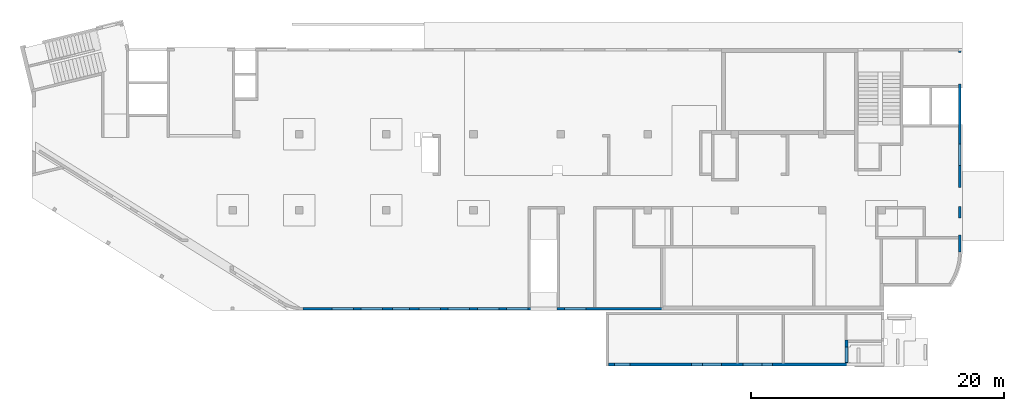
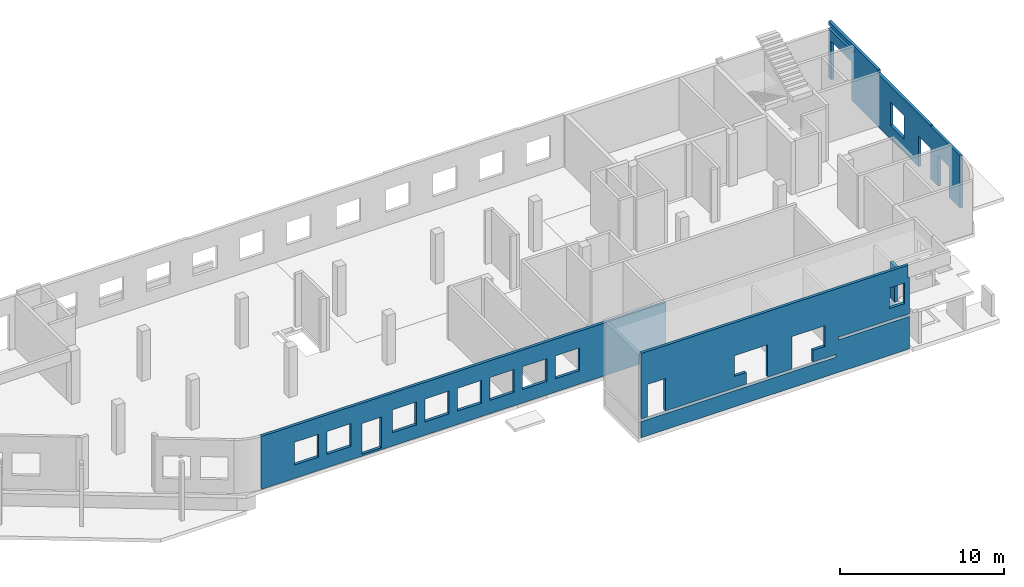
# One storey, part 7 of 8: 4 walls, 13 openings.
"""IFC4 building model written with IfcOpenShell, lengths in millimetres."""

import ifcopenshell
import ifcopenshell.guid

model = None  # the IFC model being written
_history = None  # IfcOwnerHistory: only IFC2X3 demands one
_inside = {}  # id of a spatial element -> (the spatial element, [elements in it])
_under = {}  # id of a project, library or spatial element -> (it, [spatial elements below it])
_declared = {}  # id of a project -> (the project, [libraries it declares])
_typed = {}  # id of a type object -> (the type object, [elements of that type])
_made_of = {}  # id of a material, layer set ... -> (it, [elements and type objects made of it])


def new_model(schema):
    """Start an empty IFC model of exactly this schema.

    Asked for "IFC4X3", IfcOpenShell would pick the latest addendum, in which some entities
    have other attributes; the version numbers below select the first issue.
    IFC2X3 requires an IfcOwnerHistory on every rooted entity: one is made here for all.
    """
    global model, _history
    if schema == "IFC4X3":
        model = ifcopenshell.file(schema_version=(4, 3, 0, 0))
    else:
        model = ifcopenshell.file(schema=schema)
    _inside.clear()
    _under.clear()
    _declared.clear()
    _typed.clear()
    _made_of.clear()
    _history = None
    if model.schema == "IFC2X3":
        org = make("IfcOrganization", Name="unknown")
        user = make(
            "IfcPersonAndOrganization",
            ThePerson=make("IfcPerson", FamilyName="unknown"),
            TheOrganization=org,
        )
        app = make(
            "IfcApplication",
            ApplicationDeveloper=org,
            Version="unknown",
            ApplicationFullName="unknown",
            ApplicationIdentifier="unknown",
        )
        _history = make(
            "IfcOwnerHistory",
            OwningUser=user,
            OwningApplication=app,
            ChangeAction="ADDED",
            CreationDate=0,
        )
    return model


def make(cls, **values):
    """One entity of the class cls with the attributes given. An attribute that is None is left unset."""
    return model.create_entity(
        cls, **{name: value for name, value in values.items() if value is not None}
    )


def entity(cls, *values):
    """Any entity or typed value of the class cls, its attributes in the order of the schema. None: left unset."""
    e = model.create_entity(cls)
    for i, value in enumerate(values):
        if value is not None:
            e[i] = value
    return e


def rooted(cls, **values):
    """An entity with a GlobalId (a new one), such as an element, a storey or a relation."""
    return make(cls, GlobalId=ifcopenshell.guid.new(), OwnerHistory=_history, **values)


def si_unit(unit_type, name, prefix=None):
    """IfcSIUnit, for example si_unit("LENGTHUNIT", "METRE", prefix="MILLI")."""
    return make("IfcSIUnit", UnitType=unit_type, Prefix=prefix, Name=name)


def converted_unit(unit_type, name, factor, base, dimensions=None, offset=None):
    """IfcConversionBasedUnit, such as the inch: factor (a typed value) times the base unit."""
    return make(
        "IfcConversionBasedUnit"
        if offset is None
        else "IfcConversionBasedUnitWithOffset",
        ConversionOffset=offset,
        Dimensions=None
        if dimensions is None
        else entity("IfcDimensionalExponents", *dimensions),
        UnitType=unit_type,
        Name=name,
        ConversionFactor=make(
            "IfcMeasureWithUnit", ValueComponent=factor, UnitComponent=base
        ),
    )


def derived_unit(unit_type, elements):
    """IfcDerivedUnit: a product of units, each with its exponent."""
    return make(
        "IfcDerivedUnit",
        Elements=[
            make("IfcDerivedUnitElement", Unit=unit, Exponent=power)
            for unit, power in elements
        ],
        UnitType=unit_type,
    )


def assignment(units):
    """IfcUnitAssignment: the units of a project."""
    return None if units is None else make("IfcUnitAssignment", Units=units)


def point(xyz):
    """IfcCartesianPoint."""
    return None if xyz is None else make("IfcCartesianPoint", Coordinates=xyz)


def direction(xyz):
    """IfcDirection."""
    return None if xyz is None else make("IfcDirection", DirectionRatios=xyz)


def frame(location, z_axis=None, x_axis=None):
    """IfcAxis2Placement3D, a coordinate frame: its origin and axes. An axis left out is left unset."""
    return make(
        "IfcAxis2Placement3D",
        Location=point(location),
        Axis=direction(z_axis),
        RefDirection=direction(x_axis),
    )


def origin():
    """The frame at (0, 0, 0) with its axes left unset."""
    return frame((0.0, 0.0, 0.0))


def place(relative_to, where):
    """IfcLocalPlacement: puts the frame where relative to a parent placement (None: the world)."""
    return make(
        "IfcLocalPlacement", PlacementRelTo=relative_to, RelativePlacement=where
    )


def context(
    kind, dimensions, precision=None, world=None, true_north=None, identifier=None
):
    """IfcGeometricRepresentationContext, for example the 3D "Model" context."""
    return make(
        "IfcGeometricRepresentationContext",
        ContextIdentifier=identifier,
        ContextType=kind,
        CoordinateSpaceDimension=dimensions,
        Precision=precision,
        WorldCoordinateSystem=world,
        TrueNorth=true_north,
    )


def subcontext(parent, identifier, kind, view, scale=None):
    """IfcGeometricRepresentationSubContext, for example "Body" below "Model"."""
    return make(
        "IfcGeometricRepresentationSubContext",
        ContextIdentifier=identifier,
        ContextType=kind,
        ParentContext=parent,
        TargetScale=scale,
        TargetView=view,
    )


def project(units=None, contexts=None):
    """IfcProject with its units and contexts."""
    return rooted(
        "IfcProject",
        Name="project",
        RepresentationContexts=contexts,
        UnitsInContext=assignment(units),
    )


def spatial(cls, under=None, at=None, **own):
    """A site, building, storey or space (cls), placed at a placement, below another one or the project."""
    s = rooted(cls, ObjectPlacement=at, **own)
    if under is not None:
        _under.setdefault(under.id(), (under, []))[1].append(s)
    return s


def point_list(points):
    """IfcCartesianPointList2D or 3D."""
    cls = (
        "IfcCartesianPointList2D" if len(points[0]) == 2 else "IfcCartesianPointList3D"
    )
    return make(cls, CoordList=points)


def indexed_curve(points, segments=None, self_intersect=None):
    """IfcIndexedPolyCurve: lines and arcs through numbered points (the first is 1)."""
    return make(
        "IfcIndexedPolyCurve",
        Points=point_list(points),
        Segments=segments,
        SelfIntersect=self_intersect,
    )


def outline(outer, holes=None, kind="AREA"):
    """IfcArbitraryClosedProfileDef: a profile drawn as a closed curve; with holes, ...WithVoids."""
    if holes is None:
        return make("IfcArbitraryClosedProfileDef", ProfileType=kind, OuterCurve=outer)
    return make(
        "IfcArbitraryProfileDefWithVoids",
        ProfileType=kind,
        OuterCurve=outer,
        InnerCurves=holes,
    )


def extrude(swept, where, along, depth):
    """IfcExtrudedAreaSolid: the profile swept, set in the frame where, extruded along a direction by depth."""
    return make(
        "IfcExtrudedAreaSolid",
        SweptArea=swept,
        Position=where,
        ExtrudedDirection=direction(along),
        Depth=depth,
    )


def polygons(points, faces, closed=None, point_numbers=None):
    """IfcPolygonalFaceSet: a face is its outer loop, then its inner loops; points numbered from 1."""
    made = []
    for loops in faces:
        if len(loops) == 1:
            made.append(make("IfcIndexedPolygonalFace", CoordIndex=loops[0]))
        else:
            made.append(
                make(
                    "IfcIndexedPolygonalFaceWithVoids",
                    CoordIndex=loops[0],
                    InnerCoordIndices=loops[1:],
                )
            )
    return make(
        "IfcPolygonalFaceSet",
        Coordinates=point_list(points),
        Closed=closed,
        Faces=made,
        PnIndex=point_numbers,
    )


def shape(context_of_items, identifier, shape_type, items):
    """IfcShapeRepresentation: the items that make up one representation, for example the "Body"."""
    return make(
        "IfcShapeRepresentation",
        ContextOfItems=context_of_items,
        RepresentationIdentifier=identifier,
        RepresentationType=shape_type,
        Items=items,
    )


def material(Name=None, Category=None):
    """IfcMaterial."""
    return make("IfcMaterial", Name=Name, Category=Category)


def made_of(thing, what):
    """Note that an element or type object is made of a material, layer set ...; save() writes the relation."""
    if what is not None:
        _made_of.setdefault(what.id(), (what, []))[1].append(thing)
    return thing


def type_object(cls, material=None, **own):
    """A type object (cls), such as IfcWallType, which elements share."""
    return made_of(rooted(cls, **own), material)


def element(
    cls,
    number,
    at=None,
    inside=None,
    cuts=None,
    type_object=None,
    material=None,
    context=None,
    identifier="Body",
    shape_type=None,
    held_by="IfcProductDefinitionShape",
    body=None,
    shapes=None,
    **own,
):
    """One element of the class cls, such as IfcWall. Its Tag is "e" and its number.

    at: its placement. inside: the storey or other place that contains it. cuts: it is an
    opening in that element (IfcRelVoidsElement). A single representation is given by context,
    identifier, shape_type and body (its items); several are given by shapes. held_by: the class
    of the entity that holds the representations. save() writes the other relations.
    """
    e = rooted(cls, Tag="e%d" % number, ObjectPlacement=at, **own)
    if body is not None:
        shapes = [shape(context, identifier, shape_type, body)]
    if shapes is not None:
        e.Representation = make(held_by, Representations=shapes)
    if inside is not None:
        _inside.setdefault(inside.id(), (inside, []))[1].append(e)
    if cuts is not None:
        rooted(
            "IfcRelVoidsElement", RelatingBuildingElement=cuts, RelatedOpeningElement=e
        )
    if type_object is not None:
        _typed.setdefault(type_object.id(), (type_object, []))[1].append(e)
    return made_of(e, material)


def aggregate(whole, parts):
    """IfcRelAggregates: a whole, such as a stair, and the parts it consists of."""
    return rooted("IfcRelAggregates", RelatingObject=whole, RelatedObjects=parts)


def save(model, path):
    """Write the relations noted so far, then the file.

    IfcRelAggregates (storeys below a building ...), IfcRelContainedInSpatialStructure (elements
    in a storey), IfcRelDefinesByType, IfcRelAssociatesMaterial and IfcRelDeclares: one each for
    every whole, place, type object, material and project.
    """
    for whole, parts in _under.values():
        aggregate(whole, parts)
    for where, things in _inside.values():
        rooted(
            "IfcRelContainedInSpatialStructure",
            RelatedElements=things,
            RelatingStructure=where,
        )
    for kind, things in _typed.values():
        rooted("IfcRelDefinesByType", RelatedObjects=things, RelatingType=kind)
    for what, things in _made_of.values():
        rooted("IfcRelAssociatesMaterial", RelatedObjects=things, RelatingMaterial=what)
    for by, libraries in _declared.values():
        rooted("IfcRelDeclares", RelatingContext=by, RelatedDefinitions=libraries)
    model.write(path)


model = new_model("IFC4")

# Units and contexts
model_context = context("Model", 3, precision=0.01, world=origin(), true_north=direction((6.12303176911189e-17, 1.0)))
plan_context = context("Plan", 3, precision=0.01, world=origin(), true_north=direction((6.12303176911189e-17, 1.0)))
body_context = subcontext(model_context, "Body", "Model", "MODEL_VIEW")
ifc_project = project(units=[si_unit("LENGTHUNIT", "METRE", prefix="MILLI"), si_unit("AREAUNIT", "SQUARE_METRE"), si_unit("VOLUMEUNIT", "CUBIC_METRE"), converted_unit("PLANEANGLEUNIT", "DEGREE", entity("IfcRatioMeasure", 0.0174532925199433), si_unit("PLANEANGLEUNIT", "RADIAN"), dimensions=[0, 0, 0, 0, 0, 0, 0]), si_unit("MASSUNIT", "GRAM", prefix="KILO"), derived_unit("MASSDENSITYUNIT", [(si_unit("MASSUNIT", "GRAM", prefix="KILO"), 1), (si_unit("LENGTHUNIT", "METRE"), -3)]), derived_unit("MOMENTOFINERTIAUNIT", [(si_unit("LENGTHUNIT", "METRE"), 4)]), si_unit("TIMEUNIT", "SECOND"), si_unit("FREQUENCYUNIT", "HERTZ"), si_unit("THERMODYNAMICTEMPERATUREUNIT", "DEGREE_CELSIUS"), derived_unit("THERMALTRANSMITTANCEUNIT", [(si_unit("MASSUNIT", "GRAM", prefix="KILO"), 1), (si_unit("THERMODYNAMICTEMPERATUREUNIT", "KELVIN"), -1), (si_unit("TIMEUNIT", "SECOND"), -3)]), derived_unit("VOLUMETRICFLOWRATEUNIT", [(si_unit("LENGTHUNIT", "METRE"), 3), (si_unit("TIMEUNIT", "SECOND"), -1)]), derived_unit("MASSFLOWRATEUNIT", [(si_unit("MASSUNIT", "GRAM", prefix="KILO"), 1), (si_unit("TIMEUNIT", "SECOND"), -1)]), derived_unit("ROTATIONALFREQUENCYUNIT", [(si_unit("TIMEUNIT", "SECOND"), -1)]), si_unit("ELECTRICCURRENTUNIT", "AMPERE"), si_unit("ELECTRICVOLTAGEUNIT", "VOLT"), si_unit("POWERUNIT", "WATT"), si_unit("FORCEUNIT", "NEWTON", prefix="KILO"), si_unit("ILLUMINANCEUNIT", "LUX"), si_unit("LUMINOUSFLUXUNIT", "LUMEN"), si_unit("LUMINOUSINTENSITYUNIT", "CANDELA"), derived_unit("USERDEFINED", [(si_unit("MASSUNIT", "GRAM", prefix="KILO"), -1), (si_unit("LENGTHUNIT", "METRE"), -2), (si_unit("TIMEUNIT", "SECOND"), 3), (si_unit("LUMINOUSFLUXUNIT", "LUMEN"), 1)]), derived_unit("LINEARVELOCITYUNIT", [(si_unit("LENGTHUNIT", "METRE"), 1), (si_unit("TIMEUNIT", "SECOND"), -1)]), si_unit("PRESSUREUNIT", "PASCAL"), derived_unit("USERDEFINED", [(si_unit("LENGTHUNIT", "METRE"), -2), (si_unit("MASSUNIT", "GRAM", prefix="KILO"), 1), (si_unit("TIMEUNIT", "SECOND"), -2)]), derived_unit("LINEARFORCEUNIT", [(si_unit("MASSUNIT", "GRAM", prefix="KILO"), 1), (si_unit("LENGTHUNIT", "METRE"), 1), (si_unit("TIMEUNIT", "SECOND"), -2), (si_unit("LENGTHUNIT", "METRE"), -1)]), derived_unit("PLANARFORCEUNIT", [(si_unit("MASSUNIT", "GRAM", prefix="KILO"), 1), (si_unit("LENGTHUNIT", "METRE"), 1), (si_unit("TIMEUNIT", "SECOND"), -2), (si_unit("LENGTHUNIT", "METRE"), -2)])], contexts=[model_context, plan_context])

# Site, building, storey
site_placement = place(None, origin())
site = spatial("IfcSite", under=ifc_project, at=site_placement, CompositionType="ELEMENT")
building_placement = place(site_placement, origin())
building = spatial("IfcBuilding", under=site, at=building_placement, CompositionType="ELEMENT")
storey_placement = place(building_placement, origin())
storey = spatial("IfcBuildingStorey", under=building, at=storey_placement, CompositionType="ELEMENT", Elevation=0.0)

# Wall, openings
ifc_material = material()
wall_type = type_object("IfcWallType", PredefinedType="STANDARD")
wall_1_placement = place(storey_placement, frame((21465.0002685546, -100.000773643746, -150.0)))
wall_1 = element("IfcWall", 1, at=wall_1_placement, inside=storey, type_object=wall_type, material=ifc_material, PredefinedType="NOTDEFINED", context=body_context, shape_type="Tessellation", body=[
    polygons([(6.46220325391393e-13, -100.0, 0.0), (28405.0, -100.0, 0.0), (28405.0, -100.0, 150.0), (28505.0, -100.0, 150.0), (28505.0, -100.0, 3950.0), (6.46220325391393e-13, -100.0, 3950.0), (20705.0, -100.0, 2700.0), (22405.0, -100.0, 2700.0), (22405.0, -100.0, 1000.00000000001), (20705.0, -100.0, 1000.00000000001), (2305.00000000005, -100.0, 2700.0), (4005.00000000005, -100.0, 2700.0), (4005.00000000005, -100.0, 1000.00000000001), (2305.00000000005, -100.0, 1000.00000000001), (4605.00000000006, -100.0, 2700.0), (6305.00000000006, -100.0, 2700.0), (6305.00000000006, -100.0, 1000.00000000001), (4605.00000000006, -100.0, 1000.00000000001), (9205.00000000005, -100.0, 2700.0), (10905.0000000001, -100.0, 2700.0), (10905.0000000001, -100.0, 1000.00000000001), (9205.00000000005, -100.0, 1000.00000000001), (11505.0000000001, -100.0, 2700.0), (13205.0000000001, -100.0, 2700.0), (13205.0000000001, -100.0, 1000.00000000001), (11505.0000000001, -100.0, 1000.00000000001), (13805.0, -100.0, 2700.0), (15505.0, -100.0, 2700.0), (15505.0, -100.0, 1000.00000000001), (13805.0, -100.0, 1000.00000000001), (16105.0000000001, -100.0, 2700.0), (17805.0000000001, -100.0, 2700.0), (17805.0000000001, -100.0, 1000.00000000001), (16105.0000000001, -100.0, 1000.00000000001), (18405.0000000001, -100.0, 2700.0), (20105.0, -100.0, 2700.0), (20105.0, -100.0, 1000.00000000001), (18405.0000000001, -100.0, 1000.00000000001), (7080.00000000006, -100.0, 2429.99999999804), (8430.00000000005, -100.0, 2429.99999999805), (8430.00000000005, -100.0, 150.0), (7080.00000000006, -100.0, 150.0), (28405.0, 100.0, 0.0), (2.4997118955433e-18, 100.0, 0.0), (2.4997118955433e-18, 100.0, 3950.0), (4154.99999999999, 100.0, 3950.0), (4454.99999999999, 100.0, 3950.0), (8855.0, 100.0, 3950.0), (9155.0, 100.0, 3950.0), (13365.0, 100.0, 3950.0), (13665.0, 100.0, 3950.0), (18180.0, 100.0, 3950.0), (18380.0, 100.0, 3950.0), (22605.0, 100.0, 3950.0), (22805.0, 100.0, 3950.0), (28505.0, 100.0, 3950.0), (28505.0, 100.0, 150.0), (28405.0, 100.0, 150.0), (22405.0, 100.000000000321, 2700.0), (20705.0, 100.000000000321, 2700.0), (20705.0, 100.000000000321, 1000.00000000001), (22405.0, 100.000000000321, 1000.00000000001), (4005.00000000005, 100.000000000321, 2700.0), (2305.00000000005, 100.000000000321, 2700.0), (2305.00000000005, 100.000000000321, 1000.00000000001), (4005.00000000005, 100.000000000321, 1000.00000000001), (6305.00000000006, 100.000000000321, 2700.0), (4605.00000000006, 100.000000000321, 2700.0), (4605.00000000006, 100.000000000321, 1000.00000000001), (6305.00000000006, 100.000000000321, 1000.00000000001), (10905.0000000001, 100.000000000321, 2700.0), (9205.00000000005, 100.000000000321, 2700.0), (9205.00000000005, 100.000000000321, 1000.00000000001), (10905.0000000001, 100.000000000321, 1000.00000000001), (13205.0000000001, 100.000000000321, 2700.0), (11505.0000000001, 100.000000000321, 2700.0), (11505.0000000001, 100.000000000321, 1000.00000000001), (13205.0000000001, 100.000000000321, 1000.00000000001), (15505.0, 100.000000000321, 2700.0), (13805.0, 100.000000000321, 2700.0), (13805.0, 100.000000000321, 1000.00000000001), (15505.0, 100.000000000321, 1000.00000000001), (17805.0000000001, 100.000000000321, 2700.0), (16105.0000000001, 100.000000000321, 2700.0), (16105.0000000001, 100.000000000321, 1000.00000000001), (17805.0000000001, 100.000000000321, 1000.00000000001), (20105.0, 100.000000000321, 2700.0), (18405.0000000001, 100.000000000321, 2700.0), (18405.0000000001, 100.000000000321, 1000.00000000001), (20105.0, 100.000000000321, 1000.00000000001), (8430.00000000006, 100.0, 2429.99999999804), (7080.00000000006, 100.0, 2429.99999999804), (7080.00000000006, 100.0, 150.0), (8430.00000000006, 100.0, 150.0)], [[[1, 2, 3, 4, 5, 6], [7, 8, 9, 10], [11, 12, 13, 14], [15, 16, 17, 18], [19, 20, 21, 22], [23, 24, 25, 26], [27, 28, 29, 30], [31, 32, 33, 34], [35, 36, 37, 38], [39, 40, 41, 42]], [[43, 44, 45, 46, 47, 48, 49, 50, 51, 52, 53, 54, 55, 56, 57, 58], [59, 60, 61, 62], [63, 64, 65, 66], [67, 68, 69, 70], [71, 72, 73, 74], [75, 76, 77, 78], [79, 80, 81, 82], [83, 84, 85, 86], [87, 88, 89, 90], [91, 92, 93, 94]], [[2, 1, 44, 43]], [[44, 1, 6, 45]], [[6, 5, 56, 55, 54, 53, 52, 51, 50, 49, 48, 47, 46, 45]], [[2, 43, 58, 3]], [[4, 3, 58, 57]], [[4, 57, 56, 5]], [[60, 59, 8, 7]], [[60, 7, 10, 61]], [[61, 10, 9, 62]], [[8, 59, 62, 9]], [[64, 63, 12, 11]], [[64, 11, 14, 65]], [[65, 14, 13, 66]], [[12, 63, 66, 13]], [[68, 67, 16, 15]], [[68, 15, 18, 69]], [[69, 18, 17, 70]], [[16, 67, 70, 17]], [[72, 71, 20, 19]], [[72, 19, 22, 73]], [[73, 22, 21, 74]], [[20, 71, 74, 21]], [[76, 75, 24, 23]], [[76, 23, 26, 77]], [[77, 26, 25, 78]], [[24, 75, 78, 25]], [[80, 79, 28, 27]], [[80, 27, 30, 81]], [[81, 30, 29, 82]], [[28, 79, 82, 29]], [[84, 83, 32, 31]], [[84, 31, 34, 85]], [[85, 34, 33, 86]], [[32, 83, 86, 33]], [[88, 87, 36, 35]], [[88, 35, 38, 89]], [[89, 38, 37, 90]], [[36, 87, 90, 37]], [[91, 40, 39, 92]], [[92, 39, 42, 93]], [[93, 42, 41, 94]], [[40, 91, 94, 41]]], closed=True),
])
opening_1_placement = place(wall_1_placement, frame((-21465.0002685546, 100.000773643746, 150.0)))
element("IfcOpeningElement", 2, at=opening_1_placement, cuts=wall_1, PredefinedType="OPENING", context=body_context, shape_type="SweptSolid", body=[
    extrude(outline(indexed_curve([(-849.999999999994, -850.000000000006), (849.999999999994, -850.000000000006), (849.999999999994, 849.999999999997), (-849.999999999994, 849.999999999997), (-849.999999999994, -850.000000000006)], self_intersect=False)), frame((40720.0002685547, -200.000773643808, 1700.0), z_axis=(0.0, 1.0, 0.0), x_axis=(0.0, 0.0, -1.0)), (0.0, 0.0, 1.0), 200.000000000962),
])
opening_2_placement = place(wall_1_placement, frame((-21465.0002685546, 100.000773643746, 150.0)))
element("IfcOpeningElement", 3, at=opening_2_placement, cuts=wall_1, PredefinedType="OPENING", context=body_context, shape_type="SweptSolid", body=[
    extrude(outline(indexed_curve([(-849.999999999994, -850.000000000002), (849.999999999994, -850.000000000002), (849.999999999994, 849.999999999997), (-849.999999999994, 849.999999999997), (-849.999999999994, -850.000000000002)], self_intersect=False)), frame((38420.0002685547, -200.0007736438, 1700.0), z_axis=(0.0, 1.0, 0.0), x_axis=(0.0, 0.0, -1.0)), (0.0, 0.0, 1.0), 200.000000000962),
])
opening_3_placement = place(wall_1_placement, frame((-21465.0002685546, 100.000773643746, 150.0)))
element("IfcOpeningElement", 4, at=opening_3_placement, cuts=wall_1, PredefinedType="OPENING", context=body_context, shape_type="SweptSolid", body=[
    extrude(outline(indexed_curve([(-849.999999999994, -850.000000000002), (849.999999999994, -850.000000000002), (849.999999999994, 849.999999999997), (-849.999999999994, 849.999999999997), (-849.999999999994, -850.000000000002)], self_intersect=False)), frame((36120.0002685547, -200.000773643793, 1700.0), z_axis=(0.0, 1.0, 0.0), x_axis=(0.0, 0.0, -1.0)), (0.0, 0.0, 1.0), 200.000000000962),
])
opening_4_placement = place(wall_1_placement, frame((-21465.0002685546, 100.000773643746, 150.0)))
element("IfcOpeningElement", 5, at=opening_4_placement, cuts=wall_1, PredefinedType="OPENING", context=body_context, shape_type="SweptSolid", body=[
    extrude(outline(indexed_curve([(-849.999999999994, -850.000000000002), (849.999999999994, -850.000000000002), (849.999999999994, 849.999999999997), (-849.999999999994, 849.999999999997), (-849.999999999994, -850.000000000002)], self_intersect=False)), frame((33820.0002685547, -200.000773643785, 1700.0), z_axis=(0.0, 1.0, 0.0), x_axis=(0.0, 0.0, -1.0)), (0.0, 0.0, 1.0), 200.000000000962),
])
opening_5_placement = place(wall_1_placement, frame((-21465.0002685546, 100.000773643746, 150.0)))
element("IfcOpeningElement", 6, at=opening_5_placement, cuts=wall_1, PredefinedType="OPENING", context=body_context, shape_type="SweptSolid", body=[
    extrude(outline(indexed_curve([(-849.999999999994, -849.999999999997), (849.999999999994, -849.999999999997), (849.999999999994, 850.000000000002), (-849.999999999994, 850.000000000002), (-849.999999999994, -849.999999999997)], self_intersect=False)), frame((31520.0002685547, -200.000773643778, 1700.0), z_axis=(0.0, 1.0, 0.0), x_axis=(0.0, 0.0, -1.0)), (0.0, 0.0, 1.0), 200.000000000962),
])
opening_6_placement = place(wall_1_placement, frame((-21465.0002685546, 100.000773643746, 150.0)))
element("IfcOpeningElement", 7, at=opening_6_placement, cuts=wall_1, PredefinedType="OPENING", context=body_context, shape_type="SweptSolid", body=[
    extrude(outline(indexed_curve([(-849.999999999994, -850.000000000002), (849.999999999994, -850.000000000002), (849.999999999994, 849.999999999997), (-849.999999999994, 849.999999999997), (-849.999999999994, -850.000000000002)], self_intersect=False)), frame((26920.0002685547, -200.000773643763, 1700.0), z_axis=(0.0, 1.0, 0.0), x_axis=(0.0, 0.0, -1.0)), (0.0, 0.0, 1.0), 200.000000000962),
])
opening_7_placement = place(wall_1_placement, frame((-21465.0002685546, 100.000773643746, 150.0)))
element("IfcOpeningElement", 8, at=opening_7_placement, cuts=wall_1, PredefinedType="OPENING", context=body_context, shape_type="SweptSolid", body=[
    extrude(outline(indexed_curve([(-849.999999999994, -850.000000000002), (849.999999999994, -850.000000000002), (849.999999999994, 849.999999999997), (-849.999999999994, 849.999999999997), (-849.999999999994, -850.000000000002)], self_intersect=False)), frame((24620.0002685547, -200.000773643756, 1700.0), z_axis=(0.0, 1.0, 0.0), x_axis=(0.0, 0.0, -1.0)), (0.0, 0.0, 1.0), 200.000000000962),
])
opening_8_placement = place(wall_1_placement, frame((-21465.0002685546, 100.000773643746, 150.0)))
element("IfcOpeningElement", 9, at=opening_8_placement, cuts=wall_1, PredefinedType="OPENING", context=body_context, shape_type="SweptSolid", body=[
    extrude(outline(indexed_curve([(-849.999999999994, -849.999999999997), (849.999999999994, -849.999999999997), (849.999999999994, 850.000000000006), (-849.999999999994, 850.000000000006), (-849.999999999994, -849.999999999997)], self_intersect=False)), frame((43020.0002685547, -200.000773643815, 1700.0), z_axis=(0.0, 1.0, 0.0), x_axis=(0.0, 0.0, -1.0)), (0.0, 0.0, 1.0), 200.000000000962),
])
opening_9_placement = place(wall_1_placement, frame((-21465.0002685546, 100.000773643746, 150.0)))
element("IfcOpeningElement", 10, at=opening_9_placement, cuts=wall_1, PredefinedType="OPENING", context=body_context, shape_type="SweptSolid", body=[
    extrude(outline(indexed_curve([(-1139.99999999902, -675.000000000003), (1139.99999999902, -675.000000000003), (1139.99999999902, 674.999999999998), (-1139.99999999902, 674.999999999998), (-1139.99999999902, -675.000000000003)], self_intersect=False)), frame((29220.0002685547, -300.000773643771, 1140.0), z_axis=(0.0, 1.0, 0.0), x_axis=(0.0, 0.0, -1.0)), (0.0, 0.0, 1.0), 400.000000001942),
])

wall_2_placement = place(storey_placement, frame((73470.0002685547, 4399.99913385884, -150.0), z_axis=(0.0, 0.0, 1.0), x_axis=(0.0, 1.0, 0.0)))
wall_2 = element("IfcWall", 11, at=wall_2_placement, inside=storey, type_object=wall_type, material=ifc_material, PredefinedType="NOTDEFINED", context=body_context, shape_type="Tessellation", body=[
    polygons([(6825.00009249711, -100.000000000311, 2750.0), (8525.00009249712, -100.000000000317, 2750.0), (8525.00009249712, -100.000000000317, 1000.00000000001), (6825.00009249712, -100.000000000311, 1000.00000000001), (16100.0000924971, -99.9999999999908, 4200.0), (15900.0000924971, -99.9999999999912, 4200.0), (13170.0000924966, -99.9999999999963, 4200.0), (12970.0000924966, -99.9999999999967, 4200.0), (10070.0000924971, -99.9999999999935, 4200.0), (10070.0000924971, -99.9999999999935, 3950.0), (3650.00009249714, -99.9999999999882, 3950.0), (3650.00009249714, -99.9999999999882, 3900.0), (5.41433564649196e-13, -99.999999999995, 3900.0), (5.41433564649196e-13, -99.999999999995, 0.0), (1335.00009249712, -99.9999999999925, 0.0), (1335.00009249712, -99.9999999999925, 2279.99999999804), (2685.00009249712, -99.99999999999, 2279.99999999805), (2685.00009249712, -99.99999999999, 0.0), (3600.00009249712, -99.9999999999883, 0.0), (3600.00009249712, -99.9999999999883, 2279.99999999804), (5100.00009249712, -99.9999999999855, 2279.99999999805), (5100.00009249712, -99.9999999999855, 0.0), (13275.0000924971, -99.9999999999961, 0.0), (13275.0000924971, -99.9999999999961, 2869.99999999804), (15775.0000924971, -99.9999999999914, 2869.99999999804), (15775.0000924971, -99.9999999999914, 0.0), (16100.0000924971, -99.9999999999908, 0.0), (16100.0000924971, -99.9999999999908, 3680.0), (12970.0000924971, -99.9999999999967, 3680.0), (12970.0000924971, -99.9999999999967, 3930.0), (16100.0000924971, -99.9999999999908, 3930.0), (8525.00009249712, 99.9999999999928, 2750.0), (6825.00009249712, 100.000000000007, 2750.0), (6825.00009249712, 100.000000000007, 1000.00000000001), (8525.00009249712, 99.9999999999928, 1000.00000000001), (10070.0000924971, 99.9999999999957, 4200.0), (12970.0000924966, 100.000000000001, 4200.0), (13170.0000924966, 100.000000000002, 4200.0), (15900.0000924971, 100.000000000007, 4200.0), (16100.0000924971, 100.000000000007, 4200.0), (16100.0000924971, 100.000000000007, 3930.0), (15900.0000924971, 100.000000000007, 3930.0), (12970.0000924971, 100.000000000001, 3930.0), (12970.0000924971, 100.000000000001, 3680.0), (15900.0000924971, 100.000000000007, 3680.0), (16100.0000924971, 100.000000000007, 3680.0), (16100.0000924971, 100.000000000007, 0.0), (15900.0000924971, 100.000000000007, 0.0), (15775.0000924971, 100.000000000006, 0.0), (15775.0000924971, 100.000000000006, 2869.99999999804), (13275.0000924971, 100.000000000002, 2869.99999999804), (13275.0000924971, 100.000000000002, 0.0), (10070.0000924971, 100.000000000004, 0.0), (5100.00009249712, 100.000000000004, 0.0), (5100.00009249712, 100.000000000004, 2279.99999999805), (3600.00009249712, 100.000000000001, 2279.99999999804), (3600.00009249712, 100.000000000001, 0.0), (2685.00009249712, 100.000000000008, 0.0), (2685.00009249712, 100.000000000008, 2279.99999999805), (1335.00009249712, 100.000000000005, 2279.99999999804), (1335.00009249712, 100.000000000005, 0.0), (5.41433564649196e-13, 100.000000000003, 0.0), (5.41433564649196e-13, 100.000000000003, 3900.0), (3650.00009249714, 100.00000000001, 3900.0), (3650.00009249714, 100.000000000001, 3950.0), (5885.00009249762, 100.000000000005, 3950.0), (6485.00009249762, 100.000000000006, 3950.0), (6650.00009249762, 100.000000000007, 3950.0), (6850.00009249763, 100.000000000007, 3950.0), (10070.0000924971, 99.9999999999957, 3950.0)], [[[5, 6, 7, 8, 9, 10, 11, 12, 13, 14, 15, 16, 17, 18, 19, 20, 21, 22, 23, 24, 25, 26, 27, 28, 29, 30, 31], [1, 2, 3, 4]], [[36, 37, 38, 39, 40, 41, 42, 43, 44, 45, 46, 47, 48, 49, 50, 51, 52, 53, 54, 55, 56, 57, 58, 59, 60, 61, 62, 63, 64, 65, 66, 67, 68, 69, 70], [32, 33, 34, 35]], [[14, 62, 61, 15]], [[5, 40, 39, 38, 37, 36, 9, 8, 7, 6]], [[62, 14, 13, 63]], [[10, 70, 69, 68, 67, 66, 65, 11]], [[70, 10, 9, 36]], [[44, 29, 28, 46, 45]], [[30, 43, 42, 41, 31]], [[29, 44, 43, 30]], [[59, 17, 16, 60]], [[60, 16, 15, 61]], [[17, 59, 58, 18]], [[55, 21, 20, 56]], [[56, 20, 19, 57]], [[21, 55, 54, 22]], [[2, 1, 33, 32]], [[2, 32, 35, 3]], [[3, 35, 34, 4]], [[33, 1, 4, 34]], [[50, 25, 24, 51]], [[51, 24, 23, 52]], [[25, 50, 49, 26]], [[12, 64, 63, 13]], [[64, 12, 11, 65]], [[40, 5, 31, 41]], [[27, 47, 46, 28]], [[18, 58, 57, 19]], [[22, 54, 53, 52, 23]], [[47, 27, 26, 49, 48]]], closed=True),
])
opening_10_placement = place(wall_2_placement, frame((-4399.99913385884, 73470.0002685547, 150.0), z_axis=(0.0, 0.0, 1.0), x_axis=(0.0, -1.0, 0.0)))
element("IfcOpeningElement", 12, at=opening_10_placement, cuts=wall_2, PredefinedType="OPENING", context=body_context, shape_type="SweptSolid", body=[
    extrude(outline(indexed_curve([(-1139.99999999902, -675.0), (1139.99999999902, -675.0), (1139.99999999902, 674.999999999999), (-1139.99999999902, 674.999999999999), (-1139.99999999902, -675.0)], self_intersect=False)), frame((73670.0002685546, 6409.99922635596, 990.0), z_axis=(-1.0, 0.0, 0.0), x_axis=(0.0, 0.0, -1.0)), (0.0, 0.0, 1.0), 400.000000001936),
])
opening_11_placement = place(wall_2_placement, frame((-4399.99913385884, 73470.0002685547, 150.0), z_axis=(0.0, 0.0, 1.0), x_axis=(0.0, -1.0, 0.0)))
element("IfcOpeningElement", 13, at=opening_11_placement, cuts=wall_2, PredefinedType="OPENING", context=body_context, shape_type="SweptSolid", body=[
    extrude(outline(indexed_curve([(-1139.99999999902, -750.0), (1139.99999999902, -750.0), (1139.99999999902, 750.000000000001), (-1139.99999999902, 750.000000000001), (-1139.99999999902, -750.0)], self_intersect=False)), frame((73670.0002685547, 8749.99922635596, 990.0), z_axis=(-1.0, 0.0, 0.0), x_axis=(0.0, 0.0, -1.0)), (0.0, 0.0, 1.0), 400.000000001936),
])
opening_12_placement = place(wall_2_placement, frame((-4399.99913385884, 73470.0002685547, 150.0), z_axis=(0.0, 0.0, 1.0), x_axis=(0.0, -1.0, 0.0)))
element("IfcOpeningElement", 14, at=opening_12_placement, cuts=wall_2, PredefinedType="OPENING", context=body_context, shape_type="SweptSolid", body=[
    extrude(outline(indexed_curve([(-1599.99999999902, -1250.0), (1599.99999999902, -1250.0), (1599.99999999902, 1250.0), (-1599.99999999902, 1250.0), (-1599.99999999902, -1250.0)], self_intersect=False)), frame((73670.0002685547, 18924.999226356, 1120.0), z_axis=(-1.0, 0.0, 0.0), x_axis=(0.0, 0.0, -1.0)), (0.0, 0.0, 1.0), 400.000000001936),
])
opening_13_placement = place(wall_2_placement, frame((-4399.99913385884, 73470.0002685547, 150.0), z_axis=(0.0, 0.0, 1.0), x_axis=(0.0, -1.0, 0.0)))
element("IfcOpeningElement", 15, at=opening_13_placement, cuts=wall_2, PredefinedType="OPENING", context=body_context, shape_type="SweptSolid", body=[
    extrude(outline(indexed_curve([(-850.0, -874.999999999993), (850.0, -874.999999999993), (850.0, 874.999999999993), (-850.0, 874.999999999993), (-850.0, -874.999999999993)], self_intersect=False)), frame((73570.0002685556, 12074.999226356, 1725.0), z_axis=(-1.0, 0.0, 0.0), x_axis=(0.0, 1.0, 0.0)), (0.0, 0.0, 1.0), 200.000000000968),
])

# Walls
wall_3_placement = place(storey_placement, frame((64600.003616884, -4520.00087534259, -2100.0), z_axis=(0.0, 0.0, 1.0), x_axis=(-1.0, 0.0, 0.0)))
element("IfcWall", 16, at=wall_3_placement, inside=storey, type_object=wall_type, material=ifc_material, PredefinedType="NOTDEFINED", context=body_context, shape_type="Tessellation", body=[
    polygons([(-3.91173392339549e-14, -100.0, 2.70716782324598e-13), (18930.0000000001, -100.0, 5.41433564649196e-13), (18930.0000000001, -100.0, 1200.0), (5174.99999999996, -100.0, 1200.0), (5174.99999999996, -100.0, 1400.0), (6805.00334832934, -100.0, 1400.0), (6805.00334832934, -100.0, 2270.0), (5955.00334832934, -100.0, 2270.0), (5955.00334832934, -100.0, 3820.00000000001), (8305.00334832934, -100.0, 3820.00000000001), (8305.00334832934, -100.0, 1400.0), (8655.0, -100.0, 1400.0), (8805.0, -100.0, 1400.0), (10005.0033483293, -100.0, 1400.0), (10005.0033483293, -100.0, 3820.00000000001), (12355.0033483293, -100.0, 3820.00000000001), (12355.0033483293, -100.0, 2270.0), (11505.0033483293, -100.0, 2270.0), (11505.0033483293, -100.0, 1400.0), (17230.0000000001, -100.0, 1400.0), (17230.0000000001, -100.0, 3820.00000000001), (18480.0000000001, -100.0, 3820.00000000001), (18480.0000000001, -100.0, 1400.0), (18930.0000000001, -100.0, 1400.0), (18930.0000000001, -100.0, 6280.0), (99.9999999999947, -100.0, 6280.0), (99.9999999999947, -100.0, 5330.0), (6.0166193202702e-14, -100.0, 5330.0), (9.87247133047433e-15, -100.0, 2630.0), (5025.00000000003, -100.0, 2630.0), (5025.00000000003, -100.0, 2430.0), (6.14701045105005e-15, -100.0, 2430.0), (0.0, -100.0, 2100.0), (350.003348329325, -100.0, 5030.0), (1400.00334832933, -100.0, 5030.0), (1400.00334832933, -100.0, 3500.0), (350.003348329325, -100.0, 3500.0), (18930.0000000001, 100.0, 5.41433564649196e-13), (-3.91173392339549e-14, 100.0, 2.70716782324598e-13), (6.14701045105005e-15, 100.0, 2430.0), (5025.00000000003, 99.999999999994, 2430.0), (5025.00000000003, 99.999999999994, 2630.0), (9.87247133047433e-15, 100.0, 2630.0), (6.0166193202702e-14, 100.0, 5330.0), (99.9999999999947, 100.0, 5330.0), (99.9999999999947, 100.0, 6280.0), (18930.0000000001, 100.0, 6280.0), (18930.0000000001, 100.0, 1400.0), (18480.0000000001, 100.0, 1400.0), (18480.0000000001, 100.0, 3820.00000000001), (17230.0000000001, 100.0, 3820.00000000001), (17230.0000000001, 100.0, 1400.0), (11505.0033483293, 100.0, 1400.0), (11505.0033483293, 100.0, 2270.0), (12355.0033483293, 100.0, 2270.0), (12355.0033483293, 100.0, 3820.00000000001), (10005.0033483293, 100.0, 3820.00000000001), (10005.0033483293, 100.0, 1400.0), (8305.00334832934, 100.0, 1400.0), (8305.00334832934, 100.0, 3820.00000000001), (5955.00334832934, 100.0, 3820.00000000001), (5955.00334832934, 100.0, 2270.0), (6805.00334832934, 100.0, 2270.0), (6805.00334832934, 100.0, 1400.0), (5174.99999999996, 100.0, 1400.0), (5174.99999999996, 100.0, 1200.0), (18930.0000000001, 100.0, 1200.0), (1400.00334832933, 100.0, 5030.0), (350.003348329325, 100.0, 5030.0), (350.003348329325, 100.0, 3500.0), (1400.00334832933, 100.0, 3500.0)], [[[1, 2, 3, 4, 5, 6, 7, 8, 9, 10, 11, 12, 13, 14, 15, 16, 17, 18, 19, 20, 21, 22, 23, 24, 25, 26, 27, 28, 29, 30, 31, 32, 33], [34, 35, 36, 37]], [[38, 39, 40, 41, 42, 43, 44, 45, 46, 47, 48, 49, 50, 51, 52, 53, 54, 55, 56, 57, 58, 59, 60, 61, 62, 63, 64, 65, 66, 67], [68, 69, 70, 71]], [[47, 25, 24, 48]], [[31, 41, 40, 32]], [[42, 30, 29, 43]], [[41, 31, 30, 42]], [[66, 4, 3, 67]], [[5, 65, 64, 6]], [[4, 66, 65, 5]], [[1, 33, 32, 40, 39]], [[2, 1, 39, 38]], [[26, 25, 47, 46]], [[27, 26, 46, 45]], [[27, 45, 44, 28]], [[23, 22, 50, 49]], [[21, 20, 52, 51]], [[22, 21, 51, 50]], [[19, 18, 54, 53]], [[15, 14, 58, 57]], [[16, 15, 57, 56]], [[17, 16, 56, 55]], [[18, 17, 55, 54]], [[11, 10, 60, 59]], [[7, 6, 64, 63]], [[8, 7, 63, 62]], [[9, 8, 62, 61]], [[10, 9, 61, 60]], [[35, 34, 69, 68]], [[36, 35, 68, 71]], [[37, 36, 71, 70]], [[34, 37, 70, 69]], [[29, 28, 44, 43]], [[14, 13, 12, 11, 59, 58]], [[20, 19, 53, 52]], [[24, 23, 49, 48]], [[2, 38, 67, 3]]], closed=True),
])
wall_4_placement = place(storey_placement, frame((64500.003616884, -4420.00087534259, 0.0), z_axis=(0.0, 0.0, 1.0), x_axis=(0.0, 1.0, 0.0)))
element("IfcWall", 17, at=wall_4_placement, inside=storey, type_object=wall_type, material=ifc_material, PredefinedType="NOTDEFINED", context=body_context, shape_type="Tessellation", body=[
    polygons([(0.0, -99.9999999999946, 0.0), (1650.00007018598, -99.9999999999946, 0.0), (1850.00007018598, -99.9999999999946, 0.0), (1850.00007018598, -99.9999999999946, 330.0), (1650.000070186, -99.9999999999946, 330.0), (0.0, -99.9999999999946, 330.0), (1850.00007018598, 100.000000000003, 0.0), (0.0, 100.000000000003, 0.0), (0.0, 100.000000000003, 330.0), (1850.00007018598, 100.000000000003, 330.0), (1850.00007018598, -49.9999999999973, 0.0), (1850.00007018598, -49.9999999999973, 330.0)], [[[1, 2, 3, 4, 5, 6]], [[7, 8, 9, 10]], [[3, 2, 1, 8, 7, 11]], [[3, 11, 7, 10, 12, 4]], [[8, 1, 6, 9]], [[5, 4, 12, 10, 9, 6]]], closed=True),
    polygons([(1850.00007018598, -99.9999999999946, 530.0), (1650.000070186, -99.9999999999946, 530.0), (1300.0, -99.9999999999946, 530.0), (1300.0, 100.000000000003, 530.0), (1850.00007018598, 100.000000000003, 530.0), (1850.00007018598, -49.9999999999973, 530.0), (0.0, -99.9999999999946, 3230.0), (1650.00007018598, -99.9999999999946, 3230.0), (1850.00007018598, -99.9999999999946, 3230.0), (1850.00007018598, -49.9999999999973, 3230.0), (1850.00007018598, 100.000000000003, 3230.0), (0.0, 100.000000000003, 3230.0), (0.0, 0.0, 3230.0), (49.9999999999995, -99.9999999999946, 2929.99999999804), (49.9999999999995, 100.000000000003, 2929.99999999804), (1300.0, 100.000000000003, 2929.99999999804), (1300.0, -99.9999999999946, 2929.99999999804), (50.0, -99.9999999999946, 530.0), (50.0, 100.000000000003, 530.0), (0.0, -99.9999999999946, 530.0), (0.0, 100.000000000003, 530.0)], [[[1, 2, 3, 4, 5, 6]], [[7, 8, 9, 10, 11, 12, 13]], [[14, 15, 16, 17]], [[17, 16, 4, 3]], [[15, 14, 18, 19]], [[18, 20, 21, 19]], [[7, 13, 12, 21, 20]], [[11, 10, 9, 1, 6, 5]], [[12, 11, 5, 4, 16, 15, 19, 21]], [[9, 8, 7, 20, 18, 14, 17, 3, 2, 1]]], closed=True),
])

save(model, "model.ifc")
